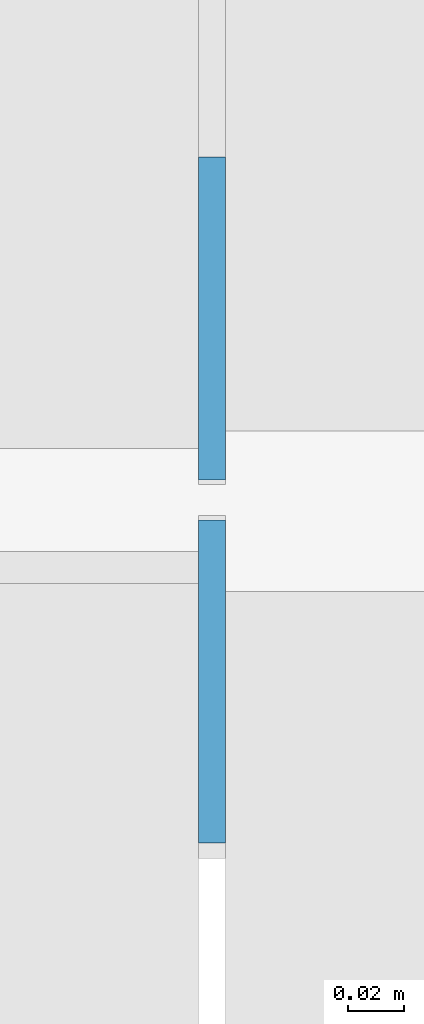
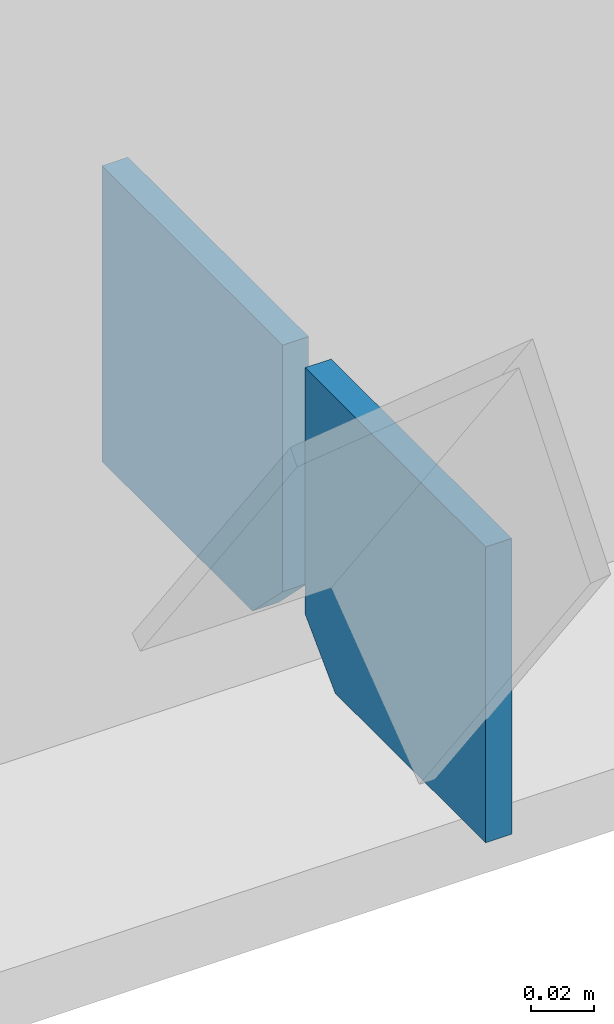
# One storey, part 582 of 1179: 2 columns, 1 element without a shape of its own.
"""IFC2X3 building model written with IfcOpenShell, lengths in millimetres."""

import ifcopenshell
import ifcopenshell.guid

model = None  # the IFC model being written
_history = None  # IfcOwnerHistory: only IFC2X3 demands one
_inside = {}  # id of a spatial element -> (the spatial element, [elements in it])
_under = {}  # id of a project, library or spatial element -> (it, [spatial elements below it])
_declared = {}  # id of a project -> (the project, [libraries it declares])
_typed = {}  # id of a type object -> (the type object, [elements of that type])
_made_of = {}  # id of a material, layer set ... -> (it, [elements and type objects made of it])


def new_model(schema):
    """Start an empty IFC model of exactly this schema.

    Asked for "IFC4X3", IfcOpenShell would pick the latest addendum, in which some entities
    have other attributes; the version numbers below select the first issue.
    IFC2X3 requires an IfcOwnerHistory on every rooted entity: one is made here for all.
    """
    global model, _history
    if schema == "IFC4X3":
        model = ifcopenshell.file(schema_version=(4, 3, 0, 0))
    else:
        model = ifcopenshell.file(schema=schema)
    _inside.clear()
    _under.clear()
    _declared.clear()
    _typed.clear()
    _made_of.clear()
    _history = None
    if model.schema == "IFC2X3":
        org = make("IfcOrganization", Name="unknown")
        user = make(
            "IfcPersonAndOrganization",
            ThePerson=make("IfcPerson", FamilyName="unknown"),
            TheOrganization=org,
        )
        app = make(
            "IfcApplication",
            ApplicationDeveloper=org,
            Version="unknown",
            ApplicationFullName="unknown",
            ApplicationIdentifier="unknown",
        )
        _history = make(
            "IfcOwnerHistory",
            OwningUser=user,
            OwningApplication=app,
            ChangeAction="ADDED",
            CreationDate=0,
        )
    return model


def make(cls, **values):
    """One entity of the class cls with the attributes given. An attribute that is None is left unset."""
    return model.create_entity(
        cls, **{name: value for name, value in values.items() if value is not None}
    )


def rooted(cls, **values):
    """An entity with a GlobalId (a new one), such as an element, a storey or a relation."""
    return make(cls, GlobalId=ifcopenshell.guid.new(), OwnerHistory=_history, **values)


def si_unit(unit_type, name, prefix=None):
    """IfcSIUnit, for example si_unit("LENGTHUNIT", "METRE", prefix="MILLI")."""
    return make("IfcSIUnit", UnitType=unit_type, Prefix=prefix, Name=name)


def assignment(units):
    """IfcUnitAssignment: the units of a project."""
    return None if units is None else make("IfcUnitAssignment", Units=units)


def point(xyz):
    """IfcCartesianPoint."""
    return None if xyz is None else make("IfcCartesianPoint", Coordinates=xyz)


def direction(xyz):
    """IfcDirection."""
    return None if xyz is None else make("IfcDirection", DirectionRatios=xyz)


def frame(location, z_axis=None, x_axis=None):
    """IfcAxis2Placement3D, a coordinate frame: its origin and axes. An axis left out is left unset."""
    return make(
        "IfcAxis2Placement3D",
        Location=point(location),
        Axis=direction(z_axis),
        RefDirection=direction(x_axis),
    )


def origin_with_axes():
    """The frame at (0, 0, 0) with the z axis (0, 0, 1) and the x axis (1, 0, 0) written out."""
    return frame((0.0, 0.0, 0.0), z_axis=(0.0, 0.0, 1.0), x_axis=(1.0, 0.0, 0.0))


def place(relative_to, where):
    """IfcLocalPlacement: puts the frame where relative to a parent placement (None: the world)."""
    return make(
        "IfcLocalPlacement", PlacementRelTo=relative_to, RelativePlacement=where
    )


def context(
    kind, dimensions, precision=None, world=None, true_north=None, identifier=None
):
    """IfcGeometricRepresentationContext, for example the 3D "Model" context."""
    return make(
        "IfcGeometricRepresentationContext",
        ContextIdentifier=identifier,
        ContextType=kind,
        CoordinateSpaceDimension=dimensions,
        Precision=precision,
        WorldCoordinateSystem=world,
        TrueNorth=true_north,
    )


def subcontext(parent, identifier, kind, view, scale=None):
    """IfcGeometricRepresentationSubContext, for example "Body" below "Model"."""
    return make(
        "IfcGeometricRepresentationSubContext",
        ContextIdentifier=identifier,
        ContextType=kind,
        ParentContext=parent,
        TargetScale=scale,
        TargetView=view,
    )


def project(units=None, contexts=None):
    """IfcProject with its units and contexts."""
    return rooted(
        "IfcProject",
        Name="project",
        RepresentationContexts=contexts,
        UnitsInContext=assignment(units),
    )


def spatial(cls, under=None, at=None, **own):
    """A site, building, storey or space (cls), placed at a placement, below another one or the project."""
    s = rooted(cls, ObjectPlacement=at, **own)
    if under is not None:
        _under.setdefault(under.id(), (under, []))[1].append(s)
    return s


def faces_of(points, faces, orient=None, outer=None):
    """IfcFace entities. A face is a list of loops; a loop is a list of indices into points, from 0.

    orient and outer hold one flag for each loop. By default every Orientation is true, the
    first loop of a face is its IfcFaceOuterBound and the others are IfcFaceBound.
    """
    made = []
    for i, loops in enumerate(faces):
        bounds = []
        for j, loop in enumerate(loops):
            is_outer = j == 0 if outer is None else outer[i][j]
            bounds.append(
                make(
                    "IfcFaceOuterBound" if is_outer else "IfcFaceBound",
                    Bound=make("IfcPolyLoop", Polygon=[points[k] for k in loop]),
                    Orientation=True if orient is None else orient[i][j],
                )
            )
        made.append(make("IfcFace", Bounds=bounds))
    return made


def faceted_brep(points, faces, orient=None, outer=None, voids=None):
    """IfcFacetedBrep: a solid bounded by flat faces; with voids (closed shells), ...WithVoids."""
    shared = [point(p) for p in points]
    hull = make("IfcClosedShell", CfsFaces=faces_of(shared, faces, orient, outer))
    if voids is None:
        return make("IfcFacetedBrep", Outer=hull)
    return make(
        "IfcFacetedBrepWithVoids",
        Outer=hull,
        Voids=[
            make(cls, CfsFaces=faces_of(shared, fs, o, b)) for cls, fs, o, b in voids
        ],
    )


def shape(context_of_items, identifier, shape_type, items):
    """IfcShapeRepresentation: the items that make up one representation, for example the "Body"."""
    return make(
        "IfcShapeRepresentation",
        ContextOfItems=context_of_items,
        RepresentationIdentifier=identifier,
        RepresentationType=shape_type,
        Items=items,
    )


def material(Name=None, Category=None):
    """IfcMaterial."""
    return make("IfcMaterial", Name=Name, Category=Category)


def made_of(thing, what):
    """Note that an element or type object is made of a material, layer set ...; save() writes the relation."""
    if what is not None:
        _made_of.setdefault(what.id(), (what, []))[1].append(thing)
    return thing


def type_object(cls, material=None, **own):
    """A type object (cls), such as IfcWallType, which elements share."""
    return made_of(rooted(cls, **own), material)


def element(
    cls,
    number,
    at=None,
    inside=None,
    cuts=None,
    type_object=None,
    material=None,
    context=None,
    identifier="Body",
    shape_type=None,
    held_by="IfcProductDefinitionShape",
    body=None,
    shapes=None,
    **own,
):
    """One element of the class cls, such as IfcWall. Its Tag is "e" and its number.

    at: its placement. inside: the storey or other place that contains it. cuts: it is an
    opening in that element (IfcRelVoidsElement). A single representation is given by context,
    identifier, shape_type and body (its items); several are given by shapes. held_by: the class
    of the entity that holds the representations. save() writes the other relations.
    """
    e = rooted(cls, Tag="e%d" % number, ObjectPlacement=at, **own)
    if body is not None:
        shapes = [shape(context, identifier, shape_type, body)]
    if shapes is not None:
        e.Representation = make(held_by, Representations=shapes)
    if inside is not None:
        _inside.setdefault(inside.id(), (inside, []))[1].append(e)
    if cuts is not None:
        rooted(
            "IfcRelVoidsElement", RelatingBuildingElement=cuts, RelatedOpeningElement=e
        )
    if type_object is not None:
        _typed.setdefault(type_object.id(), (type_object, []))[1].append(e)
    return made_of(e, material)


def aggregate(whole, parts):
    """IfcRelAggregates: a whole, such as a stair, and the parts it consists of."""
    return rooted("IfcRelAggregates", RelatingObject=whole, RelatedObjects=parts)


def save(model, path):
    """Write the relations noted so far, then the file.

    IfcRelAggregates (storeys below a building ...), IfcRelContainedInSpatialStructure (elements
    in a storey), IfcRelDefinesByType, IfcRelAssociatesMaterial and IfcRelDeclares: one each for
    every whole, place, type object, material and project.
    """
    for whole, parts in _under.values():
        aggregate(whole, parts)
    for where, things in _inside.values():
        rooted(
            "IfcRelContainedInSpatialStructure",
            RelatedElements=things,
            RelatingStructure=where,
        )
    for kind, things in _typed.values():
        rooted("IfcRelDefinesByType", RelatedObjects=things, RelatingType=kind)
    for what, things in _made_of.values():
        rooted("IfcRelAssociatesMaterial", RelatedObjects=things, RelatingMaterial=what)
    for by, libraries in _declared.values():
        rooted("IfcRelDeclares", RelatingContext=by, RelatedDefinitions=libraries)
    model.write(path)


model = new_model("IFC2X3")

# Units and contexts
model_context = context("Model", 3, precision=1e-05, world=origin_with_axes())
body_context = subcontext(model_context, "Body", "Model", "MODEL_VIEW")
ifc_project = project(units=[si_unit("LENGTHUNIT", "METRE", prefix="MILLI"), si_unit("AREAUNIT", "SQUARE_METRE"), si_unit("VOLUMEUNIT", "CUBIC_METRE"), si_unit("MASSUNIT", "GRAM", prefix="KILO"), si_unit("TIMEUNIT", "SECOND"), si_unit("PLANEANGLEUNIT", "RADIAN"), si_unit("SOLIDANGLEUNIT", "STERADIAN"), si_unit("THERMODYNAMICTEMPERATUREUNIT", "DEGREE_CELSIUS"), si_unit("LUMINOUSINTENSITYUNIT", "LUMEN")], contexts=[model_context])

# Site, building, storey
site_placement = place(None, origin_with_axes())
site = spatial("IfcSite", under=ifc_project, at=site_placement, CompositionType="ELEMENT")
building_placement = place(site_placement, origin_with_axes())
building = spatial("IfcBuilding", under=site, at=building_placement, Name="Undefined", CompositionType="ELEMENT")
storey_placement = place(building_placement, origin_with_axes())
storey = spatial("IfcBuildingStorey", under=building, at=storey_placement, Name="Undefined", CompositionType="ELEMENT", Elevation=0.0)

# Assembly, columns
assembly_placement = place(storey_placement, origin_with_axes())
assembly = element("IfcElementAssembly", 1, at=assembly_placement, inside=storey, Name="BEAM", AssemblyPlace="NOTDEFINED", PredefinedType="RIGID_FRAME")
ifc_material = material(Name="STEEL/A36")
column_type = type_object("IfcColumnType", PredefinedType="NOTDEFINED")
column_1_placement = place(assembly_placement, frame((13288.96275, 41263.093625, 3576.6375), z_axis=(0.0, -1.0, 0.0), x_axis=(0.0, 0.0, 1.0)))
column_1 = element("IfcColumn", 2, at=column_1_placement, type_object=column_type, material=ifc_material, Name="PLATE", context=body_context, shape_type="Brep", body=[
    faceted_brep([(19.0500000000002, 4.76250000000073, 57.1500000000015), (0.0, 4.76250000000073, 38.0999999999985), (0.0, -4.76250000000073, 38.0999999999985), (19.0500000000002, -4.76250000000073, 57.1500000000015), (114.300000000001, 4.76250000000073, 57.1500000000015), (114.300000000001, 4.76250000000073, -57.1500000000015), (0.0, 4.76250000000073, -57.1500000000015), (114.300000000001, -4.76250000000073, 57.1500000000015), (0.0, -4.76250000000073, -57.1500000000015), (114.300000000001, -4.76250000000073, -57.1500000000015)], [[[0, 1, 2, 3]], [[4, 5, 6, 1, 0]], [[7, 4, 0, 3]], [[8, 9, 7, 3, 2]], [[8, 6, 5, 9]], [[7, 9, 5, 4]], [[6, 8, 2, 1]]]),
])
column_2_placement = place(assembly_placement, frame((13288.96275, 41134.506125, 3576.6375), z_axis=(0.0, 1.0, 0.0), x_axis=(0.0, 0.0, 1.0)))
column_2 = element("IfcColumn", 3, at=column_2_placement, type_object=column_type, material=ifc_material, Name="PLATE", context=body_context, shape_type="Brep", body=[
    faceted_brep([(19.0500000000002, 4.76250000000073, 57.1500000000015), (0.0, 4.76250000000073, 38.0999999999985), (0.0, -4.76250000000073, 38.0999999999985), (19.0500000000002, -4.76250000000073, 57.1500000000015), (114.300000000001, 4.76250000000073, 57.1500000000015), (114.300000000001, 4.76250000000073, -57.1500000000015), (0.0, 4.76250000000073, -57.1500000000015), (114.300000000001, -4.76250000000073, 57.1500000000015), (0.0, -4.76250000000073, -57.1500000000015), (114.300000000001, -4.76250000000073, -57.1500000000015)], [[[0, 1, 2, 3]], [[4, 5, 6, 1, 0]], [[7, 4, 0, 3]], [[8, 9, 7, 3, 2]], [[8, 6, 5, 9]], [[7, 9, 5, 4]], [[6, 8, 2, 1]]]),
])
aggregate(assembly, [column_1, column_2])

save(model, "model.ifc")
